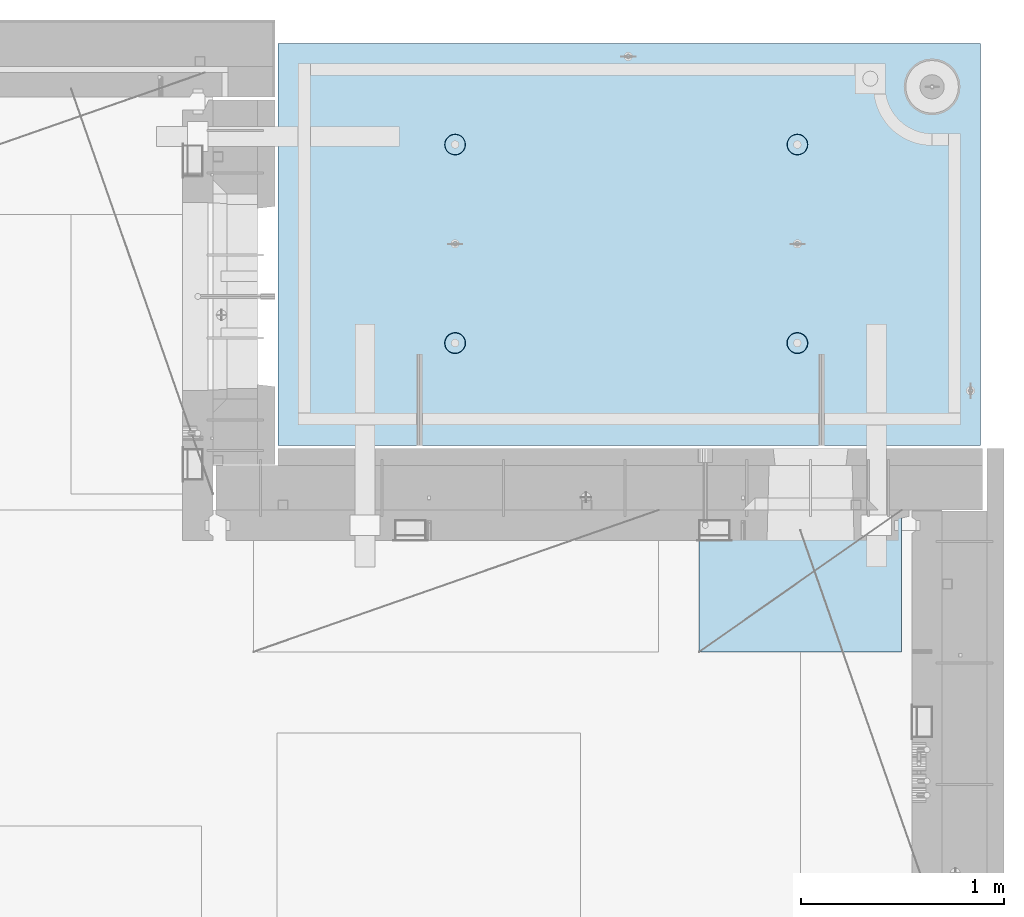
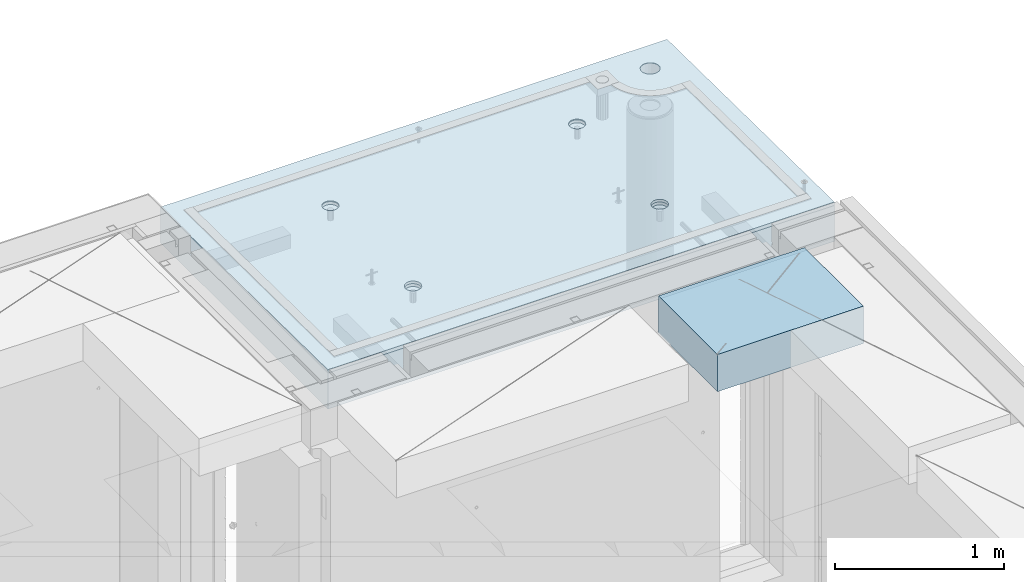
# One storey, part 212 of 352: 2 slabs, 1 plate, 2 elements without a shape of their own.
"""IFC2X3 building model written with IfcOpenShell, lengths in millimetres."""

from ifc_helpers import new_model, si_unit, frame, origin_with_axes, place, context, subcontext, project, spatial, faceted_brep, material, type_object, element, aggregate, save


model = new_model("IFC2X3")

# Units and contexts
model_context = context("Model", 3, precision=1e-05, world=origin_with_axes())
body_context = subcontext(model_context, "Body", "Model", "MODEL_VIEW")
ifc_project = project(units=[si_unit("LENGTHUNIT", "METRE", prefix="MILLI"), si_unit("AREAUNIT", "SQUARE_METRE"), si_unit("VOLUMEUNIT", "CUBIC_METRE"), si_unit("MASSUNIT", "GRAM", prefix="KILO"), si_unit("TIMEUNIT", "SECOND"), si_unit("PLANEANGLEUNIT", "RADIAN"), si_unit("SOLIDANGLEUNIT", "STERADIAN"), si_unit("THERMODYNAMICTEMPERATUREUNIT", "DEGREE_CELSIUS"), si_unit("LUMINOUSINTENSITYUNIT", "LUMEN")], contexts=[model_context])

# Site, building, storey
site_placement = place(None, origin_with_axes())
site = spatial("IfcSite", under=ifc_project, at=site_placement, CompositionType="ELEMENT")
building_placement = place(site_placement, origin_with_axes())
building = spatial("IfcBuilding", under=site, at=building_placement, CompositionType="ELEMENT")
storey_placement = place(building_placement, origin_with_axes())
storey = spatial("IfcBuildingStorey", under=building, at=storey_placement, Name="6", CompositionType="ELEMENT", Elevation=0.0)

# Assembly, slabs
assembly_1_placement = place(storey_placement, origin_with_axes())
assembly_1 = element("IfcElementAssembly", 1, at=assembly_1_placement, inside=storey, AssemblyPlace="NOTDEFINED", PredefinedType="REINFORCEMENT_UNIT")
ifc_material_1 = material(Name="CONCRETE/C35/45")
slab_type_1 = type_object("IfcSlabType", PredefinedType="NOTDEFINED")
slab_1_placement = place(assembly_1_placement, frame((31779.9998568133, 20899.9965573523, 99717.5), z_axis=(0.0, 1.0, 0.0), x_axis=(1.0, 0.0, 0.0)))
slab_1 = element("IfcSlab", 2, at=slab_1_placement, type_object=slab_type_1, material=ifc_material_1, PredefinedType="FLOOR", context=body_context, shape_type="Brep", body=[
    faceted_brep([(3287.06232936882, 9.55874156874779, 1751.46731182328), (3287.06232936882, 12.4999999999563, 1751.46731182328), (3278.5399580536, 12.4999999999563, 1734.74121634823), (3278.5399580536, 9.3480858430994, 1734.74121634823), (3265.26605352866, 12.4999999999563, 1721.46731182328), (3265.26605352866, 9.18090851265879, 1721.46731182328), (3248.5399580536, 12.4999999999563, 1712.94494050807), (3248.5399580536, 9.07357405936637, 1712.94494050807), (3229.99893839111, 12.4999999999563, 1710.00833148578), (3229.99893839111, 9.03658912732499, 1710.00833148578), (3211.45791872861, 12.4999999999563, 1712.94494050807), (3211.45791872861, 9.07357405936637, 1712.94494050807), (3194.73182325356, 12.4999999999563, 1721.46731182328), (3194.73182325356, 9.18090851267334, 1721.46731182328), (3181.45791872861, 12.4999999999563, 1734.74121634823), (3181.45791872861, 9.3480858430994, 1734.74121634823), (3172.9355474134, 12.4999999999563, 1751.46731182328), (3172.9355474134, 9.55874156874779, 1751.46731182328), (3169.99893839111, 12.4999999999563, 1770.00833148578), (3169.99893839111, 9.79225523948844, 1770.00833148578), (3172.9355474134, 12.4999999999563, 1788.54935114827), (3172.9355474134, 10.0257689102291, 1788.54935114827), (3181.45791872861, 12.4999999999563, 1805.27544662332), (3181.45791872861, 10.236424635892, 1805.27544662332), (3194.73182325356, 12.4999999999563, 1818.54935114827), (3194.73182325356, 10.4036019663181, 1818.54935114827), (3211.45791872861, 12.4999999999563, 1827.07172246349), (3211.45791872861, 10.5109364196105, 1827.07172246349), (3229.99893839111, 12.4999999999563, 1830.00833148578), (3229.99893839111, 10.5479213516664, 1830.00833148578), (3248.5399580536, 12.4999999999563, 1827.07172246349), (3248.5399580536, 10.5109364196105, 1827.07172246349), (3265.26605352866, 12.4999999999563, 1818.54935114827), (3265.26605352866, 10.4036019663181, 1818.54935114827), (3278.5399580536, 12.4999999999563, 1805.27544662332), (3278.5399580536, 10.2364246358775, 1805.27544662332), (3287.06232936882, 12.4999999999563, 1788.54935114827), (3287.06232936882, 10.0257689102291, 1788.54935114827), (3289.99893839111, 12.4999999999563, 1770.00833148578), (3289.99893839111, 9.79225523948844, 1770.00833148578), (7.41420080885291e-08, 12.4999999999927, 0.0), (-7.41420080885291e-08, -12.5, -3.63797880709171e-12), (0.0, 12.5, 1985.00366210938), (3470.0, 12.5, 0.0), (3470.00000000004, 12.4999999999563, 1985.00366210935), (3470.0, -12.5, 0.0), (2614.71871715545, -5.93617388149141, 521.168755308547), (2613.67503600632, 12.4999999999709, 520.829642746605), (2616.18047624359, 12.4999999999709, 505.010915653602), (2617.28998057371, -6.13967274603783, 505.010915653602), (2607.28293696061, -5.7526757610467, 535.738532951145), (2606.40396524136, 12.4999999999709, 535.099922616191), (2595.7125242481, -5.60710538028798, 547.296842506817), (2595.0790070157, 12.4999999999709, 546.424880841845), (2581.14006820649, -5.51366887726181, 554.715714533479), (2580.80872714612, 12.4999999999709, 553.695951606805), (2564.99000005311, -5.48147745869937, 557.271717883286), (2564.99000005311, 12.4999999999709, 556.201391844079), (2548.83993189974, -5.51366887726181, 554.715714533479), (2549.17127296011, 12.4999999999709, 553.695951606805), (2534.26747585813, -5.60710538028798, 547.296842506817), (2534.90099309052, 12.4999999999709, 546.424880841845), (2522.69706314561, -5.75267576103215, 535.738532951145), (2523.57603486487, 12.4999999999709, 535.099922616191), (2515.26128295077, -5.93617388147686, 521.168755308547), (2516.30496409991, 12.4999999999709, 520.829642746605), (2512.69001953251, -6.13967274603783, 505.010915653602), (2513.79952386263, 12.4999999999709, 505.010915653602), (2515.23823726424, -6.34326591769059, 488.84558800119), (2516.30496409991, 12.4999999999709, 489.192188560599), (2522.65977443627, -6.52701093736687, 474.256206522903), (2523.57603486487, 12.4999999999709, 474.921908691009), (2534.2301871423, -6.67288650246337, 462.673665286093), (2534.90099309052, 12.4999999999709, 463.596950465359), (2548.81688620273, -6.76656990486663, 455.235189411429), (2549.17127296011, 12.4999999999709, 456.325879700398), (2564.99000005311, -6.79885563062271, 452.67169805654), (2564.99000005311, 12.4999999999709, 453.820439463125), (2581.16311390349, -6.76656990486663, 455.235189411429), (2580.80872714612, 12.4999999999709, 456.325879700398), (2595.74981296392, -6.67288650246337, 462.673665286093), (2595.07900701571, 12.4999999999709, 463.596950465359), (2607.32022566996, -6.52701093736687, 474.256206522903), (2606.40396524136, 12.4999999999709, 474.921908691009), (2614.74176284199, -6.34326591769059, 488.84558800119), (2613.67503600632, 12.4999999999709, 489.192188560599), (924.718717121814, -5.93617388307757, 521.168755181017), (923.675035972585, 12.4999999999854, 520.829642619046), (926.180476209858, 12.4999999999854, 505.010915526043), (927.289980540074, -6.13967274762399, 505.010915526043), (917.282936926953, -5.75267576263286, 535.738532823641), (916.403965207624, 12.4999999999854, 535.099922488633), (905.712524214421, -5.60710538187413, 547.296842379335), (905.07900698197, 12.4999999999854, 546.424880714287), (891.140068172776, -5.51366887886252, 554.715714406011), (890.808727112384, 12.4999999999854, 553.695951479247), (874.990000019381, -5.48147746030008, 557.271717755822), (874.990000019381, 12.4999999999854, 556.20139171652), (858.839931865987, -5.51366887886252, 554.715714406011), (859.171272926378, 12.4999999999854, 553.695951479247), (844.267475824341, -5.60710538187413, 547.296842379335), (844.900993056792, 12.4999999999854, 546.424880714287), (832.697063111809, -5.75267576263286, 535.738532823641), (833.576034831138, 12.4999999999854, 535.099922488633), (825.261282916948, -5.93617388307757, 521.168755181017), (826.304964066177, 12.4999999999854, 520.829642619046), (822.690019498688, -6.13967274762399, 505.010915526043), (823.799523828904, 12.4999999999854, 505.010915526043), (825.238237230413, -6.34326591927675, 488.845587873602), (826.304964066174, 12.4999999999854, 489.19218843304), (832.659774402466, -6.52701093895303, 474.25620639529), (833.576034831141, 12.4999999999854, 474.921908563454), (844.230187108518, -6.67288650404953, 462.673665158458), (844.900993056788, 12.4999999999854, 463.5969503378), (858.816886168974, -6.76656990646734, 455.23518928378), (859.171272926378, 12.4999999999854, 456.32587957284), (874.990000019381, -6.79885563222342, 452.671697928887), (874.990000019381, 12.4999999999854, 453.820439335566), (891.163113869789, -6.76656990646734, 455.23518928378), (890.808727112384, 12.4999999999854, 456.32587957284), (905.749812930244, -6.67288650404953, 462.673665158458), (905.079006981974, 12.4999999999854, 463.5969503378), (917.320225636297, -6.52701093895303, 474.25620639529), (916.403965207621, 12.4999999999854, 474.921908563454), (924.741762808349, -6.34326591927675, 488.845587873602), (923.675035972588, 12.4999999999854, 489.19218843304), (924.02016693788, 6.4034111394576, 1500.93361352766), (923.67503595199, 12.4999999999854, 1500.82147367257), (926.18047618926, 12.4999999999854, 1485.00274657956), (926.555311256641, 6.20277086795249, 1485.00274657956), (916.688838773403, 6.58433162167785, 1515.29872631776), (916.403965187026, 12.4999999999854, 1515.09175354215), (905.280958178348, 6.7278571434581, 1526.69467377167), (905.079006961372, 12.4999999999854, 1526.4167117678), (890.913204613287, 6.81998112349538, 1534.0093312807), (890.808727091786, 12.4999999999854, 1533.68778253277), (874.989999998783, 6.85172034216521, 1536.52942989253), (874.989999998783, 12.4999999999854, 1536.19322277004), (859.066795384279, 6.81998112349538, 1534.0093312807), (859.17127290578, 12.4999999999854, 1533.68778253277), (844.699041819218, 6.7278571434581, 1526.69467377167), (844.900993036194, 12.4999999999854, 1526.4167117678), (833.291161224162, 6.58433162167785, 1515.29872631776), (833.57603481054, 12.4999999999854, 1515.09175354215), (825.959833059685, 6.4034111394576, 1500.93361352766), (826.304964045576, 12.4999999999854, 1500.82147367257), (823.424688740924, 6.20277086795249, 1485.00274657956), (823.799523808306, 12.4999999999854, 1485.00274657956), (825.93711110095, 6.00203761411831, 1469.06449681953), (826.304964045576, 12.4999999999854, 1469.18401948656), (833.254396317472, 5.82087370089721, 1454.68005557312), (833.57603481054, 12.4999999999854, 1454.91373961698), (844.66227690614, 5.67704728177341, 1443.26021682579), (844.90099303619, 12.4999999999854, 1443.58878139132), (859.044073415214, 5.58467987058975, 1435.9262308483), (859.17127290578, 12.4999999999854, 1436.31771062636), (874.989999998783, 5.55284766948898, 1433.39874941703), (874.989999998783, 12.4999999999854, 1433.81227038909), (890.935926582351, 5.58467987058975, 1435.9262308483), (890.808727091786, 12.4999999999854, 1436.31771062636), (905.317723091426, 5.67704728177341, 1443.26021682579), (905.079006961376, 12.4999999999854, 1443.58878139132), (916.725603680094, 5.82087370089721, 1454.68005557312), (916.403965187026, 12.4999999999854, 1454.91373961698), (924.042888896616, 6.00203761411831, 1469.06449681953), (923.67503595199, 12.4999999999854, 1469.18401948656), (2564.9899999698, 12.4999999999709, 1433.81227048016), (2564.9899999698, 5.55284767062403, 1433.39874950818), (2580.93592655335, 5.5846798717248, 1435.92623093945), (2580.8087270628, 12.4999999999709, 1436.31771071744), (2549.17127287679, 12.4999999999709, 1436.31771071744), (2549.04407338624, 5.5846798717248, 1435.92623093945), (2534.9009930072, 12.4999999999709, 1443.5887814824), (2534.66227687719, 5.67704728290846, 1443.26021691693), (2523.57603478155, 12.4999999999709, 1454.91373970805), (2523.25439628854, 5.82087370203226, 1454.68005566423), (2516.30496401659, 12.4999999999709, 1469.18401957764), (2515.93711107203, 6.00203761523881, 1469.06449691063), (2513.79952377931, 12.4999999999709, 1485.00274667064), (2513.424688712, 6.20277086908754, 1485.00274667064), (2516.30496401659, 12.4999999999709, 1500.82147376364), (2515.95983303076, 6.40341114059265, 1500.93361361872), (2523.57603478155, 12.4999999999709, 1515.09175363323), (2523.29116119523, 6.5843316228129, 1515.2987264088), (2534.90099300721, 12.4999999999709, 1526.41671185888), (2534.69904179027, 6.72785714459314, 1526.69467386269), (2549.17127287679, 12.4999999999709, 1533.68778262385), (2549.06679535531, 6.81998112463043, 1534.00933137171), (2564.9899999698, 12.4999999999709, 1536.19322286112), (2564.9899999698, 6.85172034330026, 1536.52942998354), (2580.8087270628, 12.4999999999709, 1533.68778262385), (2580.91320458428, 6.81998112463043, 1534.00933137171), (2595.07900693238, 12.4999999999709, 1526.41671185888), (2595.28095814932, 6.72785714459314, 1526.69467386269), (2606.40396515804, 12.4999999999709, 1515.09175363323), (2606.68883874436, 6.5843316228129, 1515.2987264088), (2613.675035923, 12.4999999999709, 1500.82147376364), (2614.02016690883, 6.40341114059265, 1500.93361361872), (2606.72560365105, 5.82087370203226, 1454.68005566423), (2595.3177230624, 5.67704728290846, 1443.26021691693), (2616.55531122759, 6.20277086908754, 1485.00274667064), (2614.04288886756, 6.00203761523881, 1469.06449691063), (2595.07900693239, 12.4999999999709, 1443.5887814824), (2606.40396515804, 12.4999999999709, 1454.91373970805), (2613.675035923, 12.4999999999709, 1469.18401957764), (2616.18047616028, 12.4999999999709, 1485.00274667064)], [[[0, 1, 2, 3]], [[3, 2, 4, 5]], [[5, 4, 6, 7]], [[7, 6, 8, 9]], [[9, 8, 10, 11]], [[11, 10, 12, 13]], [[13, 12, 14, 15]], [[15, 14, 16, 17]], [[17, 16, 18, 19]], [[19, 18, 20, 21]], [[21, 20, 22, 23]], [[23, 22, 24, 25]], [[25, 24, 26, 27]], [[27, 26, 28, 29]], [[29, 28, 30, 31]], [[31, 30, 32, 33]], [[33, 32, 34, 35]], [[35, 34, 36, 37]], [[37, 36, 38, 39]], [[39, 38, 1, 0]], [[40, 41, 42]], [[43, 44, 45]], [[40, 43, 45, 41]], [[46, 47, 48, 49]], [[50, 51, 47, 46]], [[52, 53, 51, 50]], [[54, 55, 53, 52]], [[56, 57, 55, 54]], [[58, 59, 57, 56]], [[59, 58, 60, 61]], [[61, 60, 62, 63]], [[63, 62, 64, 65]], [[65, 64, 66, 67]], [[67, 66, 68, 69]], [[69, 68, 70, 71]], [[71, 70, 72, 73]], [[73, 72, 74, 75]], [[75, 74, 76, 77]], [[78, 79, 77, 76]], [[80, 81, 79, 78]], [[82, 83, 81, 80]], [[84, 85, 83, 82]], [[49, 48, 85, 84]], [[86, 87, 88, 89]], [[90, 91, 87, 86]], [[92, 93, 91, 90]], [[94, 95, 93, 92]], [[96, 97, 95, 94]], [[98, 99, 97, 96]], [[99, 98, 100, 101]], [[101, 100, 102, 103]], [[103, 102, 104, 105]], [[105, 104, 106, 107]], [[107, 106, 108, 109]], [[109, 108, 110, 111]], [[111, 110, 112, 113]], [[113, 112, 114, 115]], [[115, 114, 116, 117]], [[118, 119, 117, 116]], [[120, 121, 119, 118]], [[122, 123, 121, 120]], [[124, 125, 123, 122]], [[89, 88, 125, 124]], [[126, 127, 128, 129]], [[130, 131, 127, 126]], [[132, 133, 131, 130]], [[134, 135, 133, 132]], [[136, 137, 135, 134]], [[138, 139, 137, 136]], [[140, 141, 139, 138]], [[142, 143, 141, 140]], [[143, 142, 144, 145]], [[145, 144, 146, 147]], [[147, 146, 148, 149]], [[149, 148, 150, 151]], [[151, 150, 152, 153]], [[153, 152, 154, 155]], [[155, 154, 156, 157]], [[157, 156, 158, 159]], [[159, 158, 160, 161]], [[162, 163, 161, 160]], [[164, 165, 163, 162]], [[129, 128, 165, 164]], [[166, 167, 168, 169]], [[170, 171, 167, 166]], [[172, 173, 171, 170]], [[174, 175, 173, 172]], [[176, 177, 175, 174]], [[178, 179, 177, 176]], [[180, 181, 179, 178]], [[182, 183, 181, 180]], [[183, 182, 184, 185]], [[185, 184, 186, 187]], [[187, 186, 188, 189]], [[189, 188, 190, 191]], [[191, 190, 192, 193]], [[193, 192, 194, 195]], [[195, 194, 196, 197]], [[44, 42, 41, 45], [3, 5, 7, 9, 11, 13, 15, 17, 19, 21, 23, 25, 27, 29, 31, 33, 35, 37, 39, 0], [198, 199, 168, 167, 171, 173, 175, 177, 179, 181, 183, 185, 187, 189, 191, 193, 195, 197, 200, 201], [162, 160, 158, 156, 154, 152, 150, 148, 146, 144, 142, 140, 138, 136, 134, 132, 130, 126, 129, 164], [122, 120, 118, 116, 114, 112, 110, 108, 106, 104, 102, 100, 98, 96, 94, 92, 90, 86, 89, 124], [82, 80, 78, 76, 74, 72, 70, 68, 66, 64, 62, 60, 58, 56, 54, 52, 50, 46, 49, 84]], [[169, 168, 199, 202]], [[198, 203, 202, 199]], [[201, 204, 203, 198]], [[200, 205, 204, 201]], [[197, 196, 205, 200]], [[43, 40, 42, 44], [34, 32, 30, 28, 26, 24, 22, 20, 18, 16, 14, 12, 10, 8, 6, 4, 2, 1, 38, 36], [194, 192, 190, 188, 186, 184, 182, 180, 178, 176, 174, 172, 170, 166, 169, 202, 203, 204, 205, 196], [131, 133, 135, 137, 139, 141, 143, 145, 147, 149, 151, 153, 155, 157, 159, 161, 163, 165, 128, 127], [91, 93, 95, 97, 99, 101, 103, 105, 107, 109, 111, 113, 115, 117, 119, 121, 123, 125, 88, 87], [51, 53, 55, 57, 59, 61, 63, 65, 67, 69, 71, 73, 75, 77, 79, 81, 83, 85, 48, 47]]]),
])
slab_type_2 = type_object("IfcSlabType", PredefinedType="NOTDEFINED")
slab_2_placement = place(assembly_1_placement, frame((31779.9998568132, 20899.9965573523, 99575.0), z_axis=(-1.19799915409591e-06, 0.999999999999282, 0.0), x_axis=(0.999999999999282, 1.19800000174933e-06, 0.0)))
slab_2 = element("IfcSlab", 3, at=slab_2_placement, type_object=slab_type_2, material=ifc_material_1, PredefinedType="FLOOR", context=body_context, shape_type="Brep", body=[
    faceted_brep([(2959.65048069304, -130.0, 1795.81551698422), (2959.65048069304, 130.000000000015, 1795.81551698422), (2951.52269537287, 130.000000000015, 1783.6488444481), (2951.52269537287, -130.0, 1783.6488444481), (2939.35761686434, 130.000000000015, 1775.51867349706), (2939.35761686434, -130.0, 1775.51867349706), (2925.00726809365, 130.000000000015, 1772.66274895821), (2925.00726809365, -130.0, 1772.66274895821), (2910.65635957491, 130.000000000015, 1775.51585945357), (2910.65635957491, -130.0, 1775.51585945357), (2898.48968703879, 130.000000000015, 1783.64364477374), (2898.48968703879, -130.0, 1783.64364477374), (2890.35951608775, 130.000000000015, 1795.80872328227), (2890.35951608775, -130.0, 1795.80872328227), (2887.5035915489, 130.000000000015, 1810.15907205296), (2887.5035915489, -130.0, 1810.15907205296), (2890.35670204427, 130.000000000015, 1824.5099805717), (2890.35670204427, -130.0, 1824.5099805717), (2898.48448736444, 130.000000000015, 1836.67665310783), (2898.48448736444, -130.0, 1836.67665310783), (2910.64956587296, 130.000000000015, 1844.80682405887), (2910.64956587296, -130.0, 1844.80682405887), (2924.99991464366, 130.000000000015, 1847.66274859772), (2924.99991464366, -130.0, 1847.66274859772), (2939.3508231624, 130.000000000015, 1844.80963810235), (2939.3508231624, -130.0, 1844.80963810235), (2951.51749569851, 130.000000000015, 1836.68185278219), (2951.51749569851, -130.0, 1836.68185278219), (2959.64766664955, 130.000000000015, 1824.51677427365), (2959.64766664955, -130.0, 1824.51677427365), (2962.50359118841, 130.000000000015, 1810.16642550296), (2962.50359118841, -130.0, 1810.16642550296), (3470.0, -130.0, -2.20097717829049e-09), (0.0, -130.0, -3.63797880709171e-12), (0.0, 130.0, -1.81898940354586e-12), (3470.0, 130.0, -2.20097717829049e-09), (3470.00048828125, -130.0, 1985.00366210938), (3470.00048828125, 130.0, 1985.00366210938), (0.000559809086553287, -130.0, 1985.00366210938), (0.000559809086553287, 130.0, 1985.00366210938), (890.443701616427, -110.0, 1437.44815412734), (904.382128602592, -110.0, 1444.55010256952), (915.443737652884, -110.0, 1455.61166772744), (922.54574140269, -110.0, 1469.55006653296), (924.992946242415, -110.0, 1485.00091139648), (922.545802711662, -110.0, 1500.4517659704), (915.443854269477, -110.0, 1514.39019295657), (904.382289111563, -110.0, 1525.45180200686), (890.44389030604, -110.0, 1532.55380575666), (874.993045442512, -110.0, 1535.00101059639), (859.5421908686, -110.0, 1532.55386706564), (845.603763882435, -110.0, 1525.45191862345), (834.542154832139, -110.0, 1514.39035346554), (827.440151082337, -110.0, 1500.45195466001), (824.992946242612, -110.0, 1485.00110979649), (827.440089773365, -110.0, 1469.55025522257), (834.542038215546, -110.0, 1455.61182823641), (845.603603373464, -110.0, 1444.55021918611), (859.542002178987, -110.0, 1437.44821543631), (874.992847042511, -110.0, 1435.00101059658), (923.678013579975, -130.0, 1500.81964109834), (926.183422432889, -130.0, 1485.00090903458), (916.406971127264, -130.0, 1515.08993539371), (905.082035370349, -130.0, 1526.41491608806), (890.811769926597, -130.0, 1533.68601516524), (874.993047804415, -130.0, 1536.19148678686), (859.174315740653, -130.0, 1533.68607793395), (844.904021445287, -130.0, 1526.41503548124), (833.579040750941, -130.0, 1515.09009972432), (826.307941673756, -130.0, 1500.81983428057), (823.802470052138, -130.0, 1485.00111215839), (826.307878905049, -130.0, 1469.18238009463), (833.578921357763, -130.0, 1454.91208579926), (844.903857114674, -130.0, 1443.58710510491), (859.17412255843, -130.0, 1436.31600602773), (874.992844680608, -130.0, 1433.81053440611), (890.811576744374, -130.0, 1436.31594325902), (905.081871039736, -130.0, 1443.58698571173), (916.406851734086, -130.0, 1454.91192146865), (923.677950811267, -130.0, 1469.1821869124), (890.441757333232, -110.0, 457.456323075745), (904.380184319398, -110.0, 464.558271517926), (915.44179336969, -110.0, 475.619836675844), (922.543797119495, -110.0, 489.558235481371), (924.991001959221, -110.0, 505.009080344891), (922.543858428468, -110.0, 520.459934918807), (915.441909986286, -110.0, 534.398361904972), (904.380344828369, -110.0, 545.459970955264), (890.441946022846, -110.0, 552.56197470507), (874.991101159318, -110.0, 555.009179544795), (859.540246585406, -110.0, 552.562036014042), (845.60181959924, -110.0, 545.460087571857), (834.540210548948, -110.0, 534.398522413943), (827.438206799143, -110.0, 520.46012360842), (824.991001959417, -110.0, 505.009278744892), (827.43814549017, -110.0, 489.558424170984), (834.540093932352, -110.0, 475.619997184815), (845.601659090269, -110.0, 464.558388134519), (859.540057895792, -110.0, 457.456384384717), (874.99090275932, -110.0, 455.009179544992), (923.676069296784, -130.0, 520.827810046754), (926.181478149694, -130.0, 505.009077982988), (916.405026844073, -130.0, 535.098104342116), (905.080091087159, -130.0, 546.423085036466), (890.809825643402, -130.0, 553.694184113647), (874.991103521224, -130.0, 556.199655735272), (859.172371457458, -130.0, 553.694246882354), (844.902077162096, -130.0, 546.423204429644), (833.57709646775, -130.0, 535.098268672729), (826.305997390566, -130.0, 520.828003228977), (823.800525768944, -130.0, 505.009281106795), (826.305934621854, -130.0, 489.190549043033), (833.576977074568, -130.0, 474.920254747667), (844.901912831479, -130.0, 463.595274053321), (859.172178275239, -130.0, 456.32417497614), (874.990900397414, -130.0, 453.818703354518), (890.809632461183, -130.0, 456.324112207432), (905.079926756542, -130.0, 463.595154660143), (916.404907450891, -130.0, 474.920090417054), (923.676006528072, -130.0, 489.19035586081), (2580.44175736364, -110.0, 457.452970243303), (2594.3801843498, -110.0, 464.554918685484), (2605.4417934001, -110.0, 475.616483843402), (2612.54379714991, -110.0, 489.554882648928), (2614.99100198962, -110.0, 505.005727512449), (2612.54385845887, -110.0, 520.456582086365), (2605.44191001669, -110.0, 534.39500907253), (2594.38034485878, -110.0, 545.456618122822), (2580.44194605325, -110.0, 552.558621872628), (2564.99110118972, -110.0, 555.005826712353), (2549.54024661581, -110.0, 552.5586831816), (2535.60181962965, -110.0, 545.456734739415), (2524.54021057935, -110.0, 534.395169581501), (2517.43820682954, -110.0, 520.456770775978), (2514.99100198982, -110.0, 505.00592591245), (2517.43814552058, -110.0, 489.555071338542), (2524.54009396276, -110.0, 475.616644352373), (2535.60165912067, -110.0, 464.555035302077), (2549.5400579262, -110.0, 457.453031552275), (2564.99090278973, -110.0, 455.00582671255), (2613.67606932719, -130.0, 520.824457214312), (2616.1814781801, -130.0, 505.005725150546), (2606.40502687448, -130.0, 535.094751509674), (2595.08009111756, -130.0, 546.419732204024), (2580.80982567381, -130.0, 553.690831281205), (2564.99110355163, -130.0, 556.19630290283), (2549.17237148786, -130.0, 553.690894049912), (2534.9020771925, -130.0, 546.419851597202), (2523.57709649815, -130.0, 535.094915840287), (2516.30599742097, -130.0, 520.824650396535), (2513.80052579935, -130.0, 505.005928274353), (2516.30593465226, -130.0, 489.187196210591), (2523.57697710497, -130.0, 474.916901915225), (2534.90191286189, -130.0, 463.591921220879), (2549.17217830564, -130.0, 456.320822143698), (2564.99090042782, -130.0, 453.815350522076), (2580.80963249159, -130.0, 456.32075937499), (2595.07992678695, -130.0, 463.591801827701), (2606.4049074813, -130.0, 474.916737584612), (2613.67600655848, -130.0, 489.187003028368), (2580.44370158411, -110.0, 1437.44480125841), (2594.38212857028, -110.0, 1444.5467497006), (2605.44373762057, -110.0, 1455.60831485851), (2612.54574137038, -110.0, 1469.54671366404), (2614.9929462101, -110.0, 1484.99755852756), (2612.54580267935, -110.0, 1500.44841310148), (2605.44385423717, -110.0, 1514.38684008764), (2594.38228907925, -110.0, 1525.44844913793), (2580.44389027373, -110.0, 1532.55045288774), (2564.9930454102, -110.0, 1534.99765772746), (2549.54219083629, -110.0, 1532.55051419671), (2535.60376385012, -110.0, 1525.44856575453), (2524.54215479983, -110.0, 1514.38700059661), (2517.44015105002, -110.0, 1500.44860179109), (2514.99294621029, -110.0, 1484.99775692756), (2517.44008974105, -110.0, 1469.54690235365), (2524.54203818323, -110.0, 1455.60847536748), (2535.60360334115, -110.0, 1444.54686631719), (2549.54200214667, -110.0, 1437.44486256739), (2564.9928470102, -110.0, 1434.99765772766), (2613.67801354766, -130.0, 1500.81628822942), (2616.18342240057, -130.0, 1484.99755616566), (2606.40697109495, -130.0, 1515.08658252479), (2595.08203533804, -130.0, 1526.41156321914), (2580.81176989429, -130.0, 1533.68266229632), (2564.9930477721, -130.0, 1536.18813391794), (2549.17431570834, -130.0, 1533.68272506502), (2534.90402141297, -130.0, 1526.41168261231), (2523.57904071863, -130.0, 1515.0867468554), (2516.30794164144, -130.0, 1500.81648141164), (2513.80247001983, -130.0, 1484.99775928947), (2516.30787887274, -130.0, 1469.1790272257), (2523.57892132545, -130.0, 1454.90873293034), (2534.90385708237, -130.0, 1443.58375223599), (2549.17412252611, -130.0, 1436.31265315881), (2564.99284464829, -130.0, 1433.80718153719), (2580.81157671207, -130.0, 1436.3125903901), (2595.08187100743, -130.0, 1443.58363284281), (2606.40685170178, -130.0, 1454.90856859972), (2613.67795077896, -130.0, 1469.17883404348), (3278.54339977372, -130.0, 1734.73471172154), (3265.26946891338, -130.0, 1721.46083353204), (3248.54335652997, -130.0, 1712.93849540142), (3230.00233104128, -130.0, 1710.00192316452), (3211.46131720506, -130.0, 1712.93856897219), (3194.73523863843, -130.0, 1721.46097347196), (3181.46136044892, -130.0, 1734.73490433231), (3172.9390223183, -130.0, 1751.46101671571), (3170.0024500814, -130.0, 1770.0020422044), (3172.93909588907, -130.0, 1788.54305604063), (3181.46150038884, -130.0, 1805.26913460726), (3194.73543124919, -130.0, 1818.54301279676), (3211.46154363259, -130.0, 1827.06535092738), (3230.00256912128, -130.0, 1830.00192316428), (3248.54358295751, -130.0, 1827.06527735662), (3265.26966152415, -130.0, 1818.54287285685), (3278.54353971364, -130.0, 1805.2689419965), (3287.06587784427, -130.0, 1788.5428296131), (3290.00245008117, -130.0, 1770.0018041244), (3287.0658042735, -130.0, 1751.46079028817), (3278.54353971364, 130.0, 1805.2689419965), (3287.06587784427, 130.0, 1788.5428296131), (3265.26966152415, 130.0, 1818.54287285685), (3248.54358295751, 130.0, 1827.06527735662), (3230.00256912128, 130.0, 1830.00192316428), (3211.46154363259, 130.0, 1827.06535092738), (3194.73543124919, 130.0, 1818.54301279676), (3181.46150038884, 130.0, 1805.26913460726), (3172.93909588907, 130.0, 1788.54305604063), (3170.0024500814, 130.0, 1770.0020422044), (3172.9390223183, 130.0, 1751.46101671571), (3181.46136044892, 130.0, 1734.73490433231), (3194.73523863843, 130.0, 1721.46097347196), (3211.46131720506, 130.0, 1712.93856897219), (3230.00233104128, 130.0, 1710.00192316452), (3248.54335652997, 130.0, 1712.93849540142), (3265.26946891338, 130.0, 1721.46083353204), (3278.54339977372, 130.0, 1734.73471172154), (3287.0658042735, 130.0, 1751.46079028817), (3290.00245008117, 130.0, 1770.0018041244)], [[[0, 1, 2, 3]], [[3, 2, 4, 5]], [[5, 4, 6, 7]], [[7, 6, 8, 9]], [[9, 8, 10, 11]], [[11, 10, 12, 13]], [[13, 12, 14, 15]], [[15, 14, 16, 17]], [[17, 16, 18, 19]], [[19, 18, 20, 21]], [[21, 20, 22, 23]], [[23, 22, 24, 25]], [[25, 24, 26, 27]], [[27, 26, 28, 29]], [[29, 28, 30, 31]], [[31, 30, 1, 0]], [[32, 33, 34, 35]], [[36, 32, 35, 37]], [[38, 36, 37, 39]], [[33, 38, 39, 34]], [[40, 41, 42, 43, 44, 45, 46, 47, 48, 49, 50, 51, 52, 53, 54, 55, 56, 57, 58, 59]], [[60, 45, 44, 61]], [[62, 46, 45, 60]], [[63, 47, 46, 62]], [[64, 48, 47, 63]], [[65, 49, 48, 64]], [[66, 50, 49, 65]], [[67, 51, 50, 66]], [[68, 52, 51, 67]], [[69, 53, 52, 68]], [[70, 54, 53, 69]], [[71, 55, 54, 70]], [[72, 56, 55, 71]], [[73, 57, 56, 72]], [[74, 58, 57, 73]], [[75, 59, 58, 74]], [[76, 40, 59, 75]], [[77, 41, 40, 76]], [[78, 42, 41, 77]], [[79, 43, 42, 78]], [[61, 44, 43, 79]], [[80, 81, 82, 83, 84, 85, 86, 87, 88, 89, 90, 91, 92, 93, 94, 95, 96, 97, 98, 99]], [[100, 85, 84, 101]], [[102, 86, 85, 100]], [[103, 87, 86, 102]], [[104, 88, 87, 103]], [[105, 89, 88, 104]], [[106, 90, 89, 105]], [[107, 91, 90, 106]], [[108, 92, 91, 107]], [[109, 93, 92, 108]], [[110, 94, 93, 109]], [[111, 95, 94, 110]], [[112, 96, 95, 111]], [[113, 97, 96, 112]], [[114, 98, 97, 113]], [[115, 99, 98, 114]], [[116, 80, 99, 115]], [[117, 81, 80, 116]], [[118, 82, 81, 117]], [[119, 83, 82, 118]], [[101, 84, 83, 119]], [[120, 121, 122, 123, 124, 125, 126, 127, 128, 129, 130, 131, 132, 133, 134, 135, 136, 137, 138, 139]], [[140, 125, 124, 141]], [[142, 126, 125, 140]], [[143, 127, 126, 142]], [[144, 128, 127, 143]], [[145, 129, 128, 144]], [[146, 130, 129, 145]], [[147, 131, 130, 146]], [[148, 132, 131, 147]], [[149, 133, 132, 148]], [[150, 134, 133, 149]], [[151, 135, 134, 150]], [[152, 136, 135, 151]], [[153, 137, 136, 152]], [[154, 138, 137, 153]], [[155, 139, 138, 154]], [[156, 120, 139, 155]], [[157, 121, 120, 156]], [[158, 122, 121, 157]], [[159, 123, 122, 158]], [[141, 124, 123, 159]], [[160, 161, 162, 163, 164, 165, 166, 167, 168, 169, 170, 171, 172, 173, 174, 175, 176, 177, 178, 179]], [[180, 165, 164, 181]], [[182, 166, 165, 180]], [[183, 167, 166, 182]], [[184, 168, 167, 183]], [[185, 169, 168, 184]], [[186, 170, 169, 185]], [[187, 171, 170, 186]], [[188, 172, 171, 187]], [[189, 173, 172, 188]], [[190, 174, 173, 189]], [[191, 175, 174, 190]], [[192, 176, 175, 191]], [[193, 177, 176, 192]], [[194, 178, 177, 193]], [[195, 179, 178, 194]], [[196, 160, 179, 195]], [[197, 161, 160, 196]], [[198, 162, 161, 197]], [[199, 163, 162, 198]], [[181, 164, 163, 199]], [[32, 36, 38, 33], [3, 5, 7, 9, 11, 13, 15, 17, 19, 21, 23, 25, 27, 29, 31, 0], [198, 197, 196, 195, 194, 193, 192, 191, 190, 189, 188, 187, 186, 185, 184, 183, 182, 180, 181, 199], [158, 157, 156, 155, 154, 153, 152, 151, 150, 149, 148, 147, 146, 145, 144, 143, 142, 140, 141, 159], [118, 117, 116, 115, 114, 113, 112, 111, 110, 109, 108, 107, 106, 105, 104, 103, 102, 100, 101, 119], [78, 77, 76, 75, 74, 73, 72, 71, 70, 69, 68, 67, 66, 65, 64, 63, 62, 60, 61, 79], [200, 201, 202, 203, 204, 205, 206, 207, 208, 209, 210, 211, 212, 213, 214, 215, 216, 217, 218, 219]], [[216, 220, 221, 217]], [[215, 222, 220, 216]], [[214, 223, 222, 215]], [[213, 224, 223, 214]], [[212, 225, 224, 213]], [[211, 226, 225, 212]], [[210, 227, 226, 211]], [[209, 228, 227, 210]], [[208, 229, 228, 209]], [[207, 230, 229, 208]], [[206, 231, 230, 207]], [[205, 232, 231, 206]], [[204, 233, 232, 205]], [[203, 234, 233, 204]], [[202, 235, 234, 203]], [[201, 236, 235, 202]], [[200, 237, 236, 201]], [[219, 238, 237, 200]], [[218, 239, 238, 219]], [[217, 221, 239, 218]], [[37, 35, 34, 39], [26, 24, 22, 20, 18, 16, 14, 12, 10, 8, 6, 4, 2, 1, 30, 28], [220, 222, 223, 224, 225, 226, 227, 228, 229, 230, 231, 232, 233, 234, 235, 236, 237, 238, 239, 221]]]),
])
aggregate(assembly_1, [slab_1, slab_2])

# Assembly, plate
assembly_2_placement = place(storey_placement, origin_with_axes())
assembly_2 = element("IfcElementAssembly", 4, at=assembly_2_placement, inside=storey, Name="Steel Assembly", AssemblyPlace="NOTDEFINED", PredefinedType="NOTDEFINED")
ifc_material_2 = material()
plate_type = type_object("IfcPlateType", PredefinedType="NOTDEFINED")
plate_placement = place(assembly_2_placement, frame((34860.0, 20580.0000000707, 99595.3), z_axis=(0.0, -1.0, 0.0), x_axis=(-1.0, 3.00000001838171e-08, 0.0)))
plate = element("IfcPlate", 5, at=plate_placement, type_object=plate_type, material=ifc_material_2, Name="RE1_1/2", context=body_context, shape_type="Brep", body=[
    faceted_brep([(1.81898940354586e-12, -135.0, 1.81898940354586e-12), (0.0, -135.0, 699.999999999996), (0.0, 135.0, 699.999999999996), (1.81898940354586e-12, 135.0, 1.81898940354586e-12), (999.99951171875, -135.0, 700.0), (999.99951171875, 135.0, 700.0), (1000.0, -135.0, 0.0), (1000.0, 135.0, 0.0)], [[[0, 1, 2, 3]], [[1, 4, 5, 2]], [[4, 6, 7, 5]], [[6, 0, 3, 7]], [[5, 7, 3, 2]], [[6, 4, 1, 0]]]),
])
aggregate(assembly_2, [plate])

save(model, "model.ifc")
